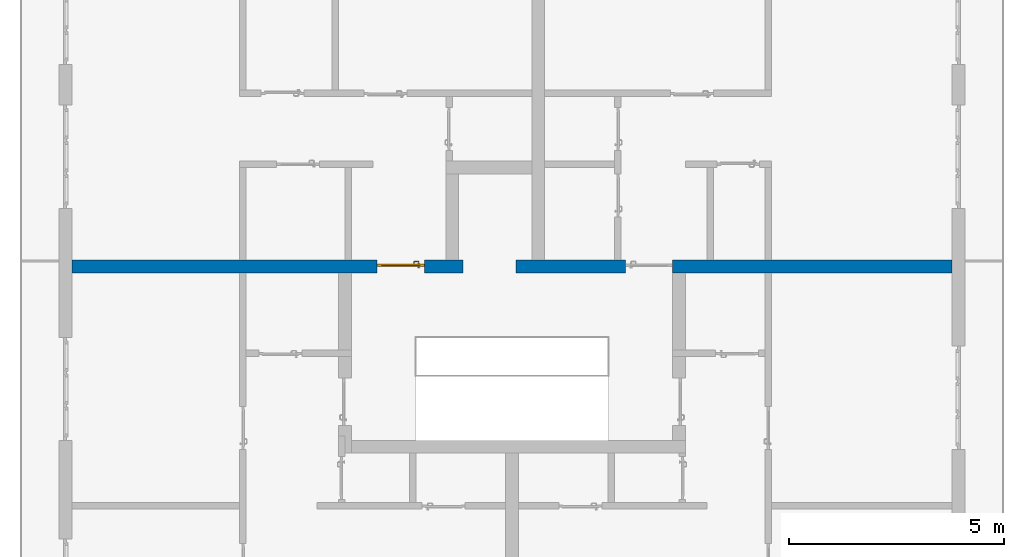
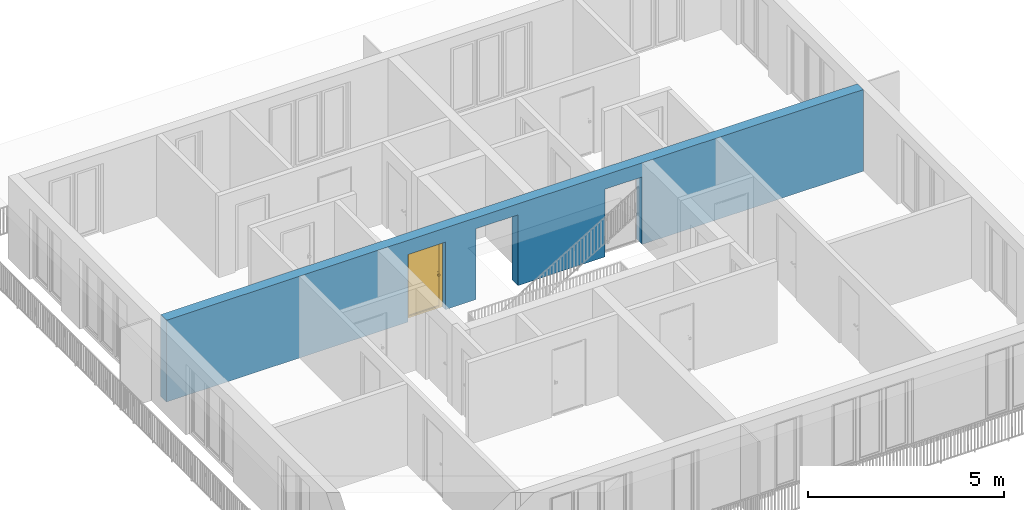
# One storey, part 16 of 54: 1 door, 1 wall, 3 openings.
"""IFC4 building model written with IfcOpenShell, lengths in metres."""

from ifc_helpers import new_model, entity, si_unit, converted_unit, derived_unit, direction, frame, origin_with_axes, place, context, subcontext, project, spatial, polygons, source, transform, mapped, material, type_object, element, fill, save


model = new_model("IFC4")

# Units and contexts
model_context = context("Model", 3, precision=1e-05, world=origin_with_axes(), true_north=direction((0.0, 1.0)))
body_context = subcontext(model_context, "Body", "Model", "MODEL_VIEW")
ifc_project = project(units=[si_unit("LENGTHUNIT", "METRE"), si_unit("AREAUNIT", "SQUARE_METRE"), si_unit("VOLUMEUNIT", "CUBIC_METRE"), converted_unit("PLANEANGLEUNIT", "DEGREE", entity("IfcPlaneAngleMeasure", 0.0174532925199), si_unit("PLANEANGLEUNIT", "RADIAN"), dimensions=[0, 0, 0, 0, 0, 0, 0]), converted_unit("TIMEUNIT", "Year", entity("IfcTimeMeasure", 31556926.0), si_unit("TIMEUNIT", "SECOND"), dimensions=[0, 0, 1, 0, 0, 0, 0]), si_unit("MASSUNIT", "GRAM", prefix="KILO"), si_unit("THERMODYNAMICTEMPERATUREUNIT", "DEGREE_CELSIUS"), si_unit("LUMINOUSINTENSITYUNIT", "LUMEN"), si_unit("ENERGYUNIT", "JOULE", prefix="MEGA"), derived_unit("THERMALCONDUCTANCEUNIT", [(si_unit("POWERUNIT", "WATT"), 1), (si_unit("LENGTHUNIT", "METRE"), -1), (si_unit("THERMODYNAMICTEMPERATUREUNIT", "KELVIN"), -1)]), derived_unit("SPECIFICHEATCAPACITYUNIT", [(si_unit("ENERGYUNIT", "JOULE"), 1), (si_unit("MASSUNIT", "GRAM", prefix="KILO"), -1), (si_unit("THERMODYNAMICTEMPERATUREUNIT", "KELVIN"), -1)]), derived_unit("MASSDENSITYUNIT", [(si_unit("MASSUNIT", "GRAM", prefix="KILO"), 1), (si_unit("VOLUMEUNIT", "CUBIC_METRE"), -1)])], contexts=[model_context])

# Site, building, storey
site_placement = place(None, origin_with_axes())
site = spatial("IfcSite", under=ifc_project, at=site_placement, CompositionType="ELEMENT")
building_placement = place(site_placement, origin_with_axes())
building = spatial("IfcBuilding", under=site, at=building_placement, CompositionType="ELEMENT")
storey_placement = place(building_placement, frame((0.0, 0.0, 6.29), z_axis=(0.0, 0.0, 1.0), x_axis=(1.0, 0.0, 0.0)))
storey = spatial("IfcBuildingStorey", under=building, at=storey_placement, Name="2. Geschoss", CompositionType="ELEMENT", Elevation=6.29)

# Wall, openings, door
ifc_material = material()
wall_type = type_object("IfcWallType", Name="300", PredefinedType="NOTDEFINED")
wall_placement = place(storey_placement, frame((-11.7421993804, 1.37118776896, 0.0), z_axis=(0.0, 0.0, 1.0), x_axis=(1.0, 0.0, 0.0)))
wall = element("IfcWall", 1, at=wall_placement, inside=storey, type_object=wall_type, material=ifc_material, Name="Wand-001", PredefinedType="NOTDEFINED", context=body_context, shape_type="Tessellation", body=[
    polygons([(9.4, 0.3, 2.2), (9.4, 0.3, 0.0), (8.5, 0.3, 0.0), (8.5, 0.3, 2.1), (7.4, 0.3, 2.1), (7.4, 0.3, 0.0), (0.3, 0.3, 0.0), (0.3, 0.3, 2.54), (20.78, 0.3, 2.54), (20.78, 0.3, 0.0), (14.28, 0.3, 0.0), (14.28, 0.3, 2.1), (13.18, 0.3, 2.1), (13.18, 0.3, 0.0), (10.63, 0.3, 0.0), (10.63, 0.3, 2.2), (9.4, 0.0, 2.2), (9.4, 0.0, 0.0), (8.5, 0.0, 0.0), (8.5, 0.0, 2.1), (7.4, 0.0, 2.1), (7.4, 0.0, 0.0), (0.3, 0.0, 0.0), (0.3, 0.0, 2.54), (20.78, 0.0, 2.54), (20.78, 0.0, 0.0), (14.28, 0.0, 0.0), (14.28, 0.0, 2.1), (13.18, 0.0, 2.1), (13.18, 0.0, 0.0), (10.63, 0.0, 0.0), (10.63, 0.0, 2.2)], [[[1, 2, 3, 4, 5, 6, 7, 8, 9, 10, 11, 12, 13, 14, 15, 16]], [[2, 1, 17, 18]], [[2, 18, 19, 3]], [[20, 4, 3, 19]], [[21, 5, 4, 20]], [[22, 6, 5, 21]], [[7, 6, 22, 23]], [[24, 8, 7, 23]], [[25, 9, 8, 24]], [[9, 25, 26, 10]], [[10, 26, 27, 11]], [[11, 27, 28, 12]], [[12, 28, 29, 13]], [[13, 29, 30, 14]], [[31, 15, 14, 30]], [[16, 15, 31, 32]], [[1, 16, 32, 17]], [[32, 31, 30, 29, 28, 27, 26, 25, 24, 23, 22, 21, 20, 19, 18, 17]]], closed=True),
])
opening_1_placement = place(wall_placement, frame((7.95, 0.0, 0.0), z_axis=(0.0, 0.0, 1.0), x_axis=(1.0, 0.0, 0.0)))
opening_1 = element("IfcOpeningElement", 2, at=opening_1_placement, cuts=wall, context=body_context, identifier="Reference", shape_type="Tessellation", body=[
    polygons([(0.55, 0.15, 0.0), (0.55, 0.15, 2.1), (0.55, -0.001, 2.1), (0.55, -0.001, 0.0), (0.55, 0.301, 0.0), (0.55, 0.301, 2.1), (-0.55, 0.15, 2.1), (-0.55, -0.001, 2.1), (-0.55, 0.301, 2.1), (-0.55, -0.001, 0.0), (-0.55, 0.15, 0.0), (-0.55, 0.301, 0.0)], [[[1, 2, 3, 4]], [[2, 1, 5, 6]], [[7, 8, 3, 2, 6, 9]], [[8, 10, 4, 3]], [[1, 4, 10, 11, 12, 5]], [[6, 5, 12, 9]], [[7, 11, 10, 8]], [[11, 7, 9, 12]]], closed=True),
])
opening_2_placement = place(wall_placement, frame((13.73, 0.0, 0.0), z_axis=(0.0, 0.0, 1.0), x_axis=(1.0, 0.0, 0.0)))
element("IfcOpeningElement", 3, at=opening_2_placement, cuts=wall, context=body_context, identifier="Reference", shape_type="Tessellation", body=[
    polygons([(0.55, 0.15, 0.0), (0.55, 0.15, 2.1), (0.55, -0.001, 2.1), (0.55, -0.001, 0.0), (0.55, 0.301, 0.0), (0.55, 0.301, 2.1), (-0.55, 0.15, 2.1), (-0.55, -0.001, 2.1), (-0.55, 0.301, 2.1), (-0.55, -0.001, 0.0), (-0.55, 0.15, 0.0), (-0.55, 0.301, 0.0)], [[[1, 2, 3, 4]], [[2, 1, 5, 6]], [[7, 8, 3, 2, 6, 9]], [[8, 10, 4, 3]], [[1, 4, 10, 11, 12, 5]], [[6, 5, 12, 9]], [[7, 11, 10, 8]], [[11, 7, 9, 12]]], closed=True),
])
opening_3_placement = place(wall_placement, frame((10.015, 0.0, 0.0), z_axis=(0.0, 0.0, 1.0), x_axis=(1.0, 0.0, 0.0)))
element("IfcOpeningElement", 4, at=opening_3_placement, cuts=wall, context=body_context, identifier="Reference", shape_type="Tessellation", body=[
    polygons([(-0.615, -0.001, 2.2), (-0.615, -0.001, 0.0), (0.615, -0.001, 0.0), (0.615, -0.001, 2.2), (-0.615, 0.301, 2.2), (-0.615, 0.301, 0.0), (0.615, 0.301, 0.0), (0.615, 0.301, 2.2)], [[[1, 2, 3, 4]], [[5, 6, 2, 1]], [[6, 7, 3, 2]], [[7, 8, 4, 3]], [[8, 5, 1, 4]], [[7, 6, 5, 8]]], closed=True),
])
door_type = type_object("IfcDoorType", Name="Eingang 01 1-Fl 26", OperationType="SINGLE_SWING_LEFT", PredefinedType="DOOR")
shared_shape = source(origin_with_axes(), body_context, "Body", "Tessellation", [
    polygons([(-0.55, -0.05, 0.0), (-0.55, -0.05, 2.1), (-0.55, -0.03, 2.1), (-0.55, -0.03, 0.0), (-0.45, -0.05, 0.0), (-0.45, -0.05, 2.0), (-0.1301, -0.05, 2.0), (-0.0001, -0.05, 2.0), (0.45, -0.05, 2.0), (0.45, -0.05, 0.0), (0.55, -0.05, 0.0), (0.55, -0.05, 2.1), (0.55, -0.03, 2.1), (0.55, -0.03, 0.0), (0.45, -0.03, 0.0), (0.45, -0.03, 2.0), (-0.0001, -0.03, 2.0), (-0.1301, -0.03, 2.0), (-0.45, -0.03, 2.0), (-0.45, -0.03, 0.0)], [[[1, 2, 3, 4]], [[1, 5, 6, 7, 8, 9, 10, 11, 12, 2]], [[2, 12, 13, 3]], [[4, 3, 13, 14, 15, 16, 17, 18, 19, 20]], [[5, 1, 4, 20]], [[6, 5, 20, 19]], [[7, 6, 19, 18]], [[8, 7, 18, 17]], [[9, 8, 17, 16]], [[10, 9, 16, 15]], [[11, 10, 15, 14]], [[12, 11, 14, 13]]], closed=True),
    polygons([(-0.55, -0.03, 0.0), (-0.55, -0.03, 2.1), (-0.55, 0.0, 2.1), (-0.55, 0.0, 0.0), (-0.48, -0.03, 0.0), (-0.48, -0.03, 2.03), (-0.1001, -0.03, 2.03), (-0.0301, -0.03, 2.03), (0.48, -0.03, 2.03), (0.48, -0.03, 0.0), (0.55, -0.03, 0.0), (0.55, -0.03, 2.1), (0.55, 0.0, 2.1), (0.55, 0.0, 0.0), (0.48, 0.0, 0.0), (0.48, 0.0, 2.03), (-0.0301, 0.0, 2.03), (-0.1001, 0.0, 2.03), (-0.48, 0.0, 2.03), (-0.48, 0.0, 0.0)], [[[1, 2, 3, 4]], [[1, 5, 6, 7, 8, 9, 10, 11, 12, 2]], [[2, 12, 13, 3]], [[4, 3, 13, 14, 15, 16, 17, 18, 19, 20]], [[5, 1, 4, 20]], [[6, 5, 20, 19]], [[7, 6, 19, 18]], [[8, 7, 18, 17]], [[9, 8, 17, 16]], [[10, 9, 16, 15]], [[11, 10, 15, 14]], [[12, 11, 14, 13]]], closed=True),
    polygons([(-0.48, 0.01, 0.0), (-0.48, 0.01, 2.03), (0.48, 0.01, 2.03), (0.48, 0.01, 0.0), (-0.48, -0.03, 0.0), (-0.48, -0.03, 2.03), (0.48, -0.03, 2.03), (0.48, -0.03, 0.0)], [[[1, 2, 3, 4]], [[1, 5, 6, 2]], [[2, 6, 7, 3]], [[3, 7, 8, 4]], [[4, 8, 5, 1]], [[8, 7, 6, 5]]], closed=True),
    polygons([(-0.445, -0.05, 0.0), (0.445, -0.05, 0.0), (0.445, -0.05, 0.05), (-0.445, -0.05, 0.05), (-0.445, -0.03, 0.0), (0.445, -0.03, 0.0), (0.445, -0.03, 0.07), (0.445, -0.035, 0.07), (-0.445, -0.035, 0.07), (-0.445, -0.03, 0.07)], [[[1, 2, 3, 4]], [[5, 6, 2, 1]], [[2, 6, 7, 8, 3]], [[4, 3, 8, 9]], [[1, 4, 9, 10, 5]], [[10, 7, 6, 5]], [[9, 8, 7, 10]]], closed=True),
    polygons([(0.4335, 0.02, 1.0733826859), (0.42, 0.02, 1.077), (0.42, 0.0199, 1.077), (0.4335, 0.0199, 1.0733826859), (0.443382685902, 0.02, 1.0635), (0.447, 0.02, 1.05), (0.443382685902, 0.02, 1.0365), (0.4335, 0.02, 1.0266173141), (0.42, 0.02, 1.023), (0.4065, 0.02, 1.0266173141), (0.396617314098, 0.02, 1.0365), (0.393, 0.02, 1.05), (0.396617314098, 0.02, 1.0635), (0.4065, 0.02, 1.0733826859), (0.4065, 0.0199, 1.0733826859), (0.42, 0.0101, 1.077), (0.4335, 0.0101, 1.0733826859), (0.443382685902, 0.0199, 1.0635), (0.447, 0.0199, 1.05), (0.443382685902, 0.0199, 1.0365), (0.4335, 0.0199, 1.0266173141), (0.42, 0.0199, 1.023), (0.4065, 0.0199, 1.0266173141), (0.396617314098, 0.0199, 1.0365), (0.393, 0.0199, 1.05), (0.396617314098, 0.0199, 1.0635), (0.4065, 0.0101, 1.0733826859), (0.42, 0.01, 1.077), (0.4335, 0.01, 1.0733826859), (0.443382685902, 0.0101, 1.0635), (0.447, 0.0101, 1.05), (0.443382685902, 0.0101, 1.0365), (0.4335, 0.0101, 1.0266173141), (0.42, 0.0101, 1.023), (0.4065, 0.0101, 1.0266173141), (0.396617314098, 0.0101, 1.0365), (0.393, 0.0101, 1.05), (0.396617314098, 0.0101, 1.0635), (0.4065, 0.01, 1.0733826859), (0.396617314098, 0.01, 1.0635), (0.393, 0.01, 1.05), (0.396617314098, 0.01, 1.0365), (0.4065, 0.01, 1.0266173141), (0.42, 0.01, 1.023), (0.4335, 0.01, 1.0266173141), (0.443382685902, 0.01, 1.0365), (0.447, 0.01, 1.05), (0.443382685902, 0.01, 1.0635)], [[[1, 2, 3, 4]], [[2, 1, 5, 6, 7, 8, 9, 10, 11, 12, 13, 14]], [[2, 14, 15, 3]], [[4, 3, 16, 17]], [[5, 1, 4, 18]], [[6, 5, 18, 19]], [[7, 6, 19, 20]], [[8, 7, 20, 21]], [[9, 8, 21, 22]], [[10, 9, 22, 23]], [[11, 10, 23, 24]], [[12, 11, 24, 25]], [[13, 12, 25, 26]], [[14, 13, 26, 15]], [[3, 15, 27, 16]], [[17, 16, 28, 29]], [[18, 4, 17, 30]], [[19, 18, 30, 31]], [[20, 19, 31, 32]], [[21, 20, 32, 33]], [[22, 21, 33, 34]], [[23, 22, 34, 35]], [[24, 23, 35, 36]], [[25, 24, 36, 37]], [[26, 25, 37, 38]], [[15, 26, 38, 27]], [[16, 27, 39, 28]], [[28, 39, 40, 41, 42, 43, 44, 45, 46, 47, 48, 29]], [[30, 17, 29, 48]], [[31, 30, 48, 47]], [[32, 31, 47, 46]], [[33, 32, 46, 45]], [[34, 33, 45, 44]], [[35, 34, 44, 43]], [[36, 35, 43, 42]], [[37, 36, 42, 41]], [[38, 37, 41, 40]], [[27, 38, 40, 39]]], closed=True),
    polygons([(0.412532169224, 0.019, 0.959692280177), (0.413279754556, 0.019, 0.961639806549), (0.40705, 0.019, 0.972430057958), (0.397569942042, 0.019, 0.96295), (0.415, 0.019, 0.952886751346), (0.415, 0.019, 0.9544), (0.412532169224, 0.02, 0.959692280177), (0.413279754556, 0.02, 0.961639806549), (0.414624817685, 0.02, 0.965143815798), (0.414624817685, 0.019, 0.965143815798), (0.42, 0.019, 0.967425445323), (0.42, 0.019, 0.9759), (0.407, 0.019, 0.972516660498), (0.397483339502, 0.019, 0.963), (0.415, 0.019, 0.95), (0.3941, 0.019, 0.95), (0.415, 0.019, 0.947113248654), (0.415, 0.019, 0.941339745962), (0.415, 0.019, 0.9375), (0.415, 0.02, 0.9375), (0.415, 0.02, 0.941339745962), (0.415, 0.02, 0.947113248654), (0.415, 0.02, 0.95), (0.415, 0.02, 0.952886751346), (0.415, 0.02, 0.9544), (0.396703916638, 0.02, 0.96345), (0.40655, 0.02, 0.973296083362), (0.42, 0.02, 0.9769), (0.42, 0.02, 0.967425445323), (0.425375182315, 0.019, 0.965143815798), (0.426720245444, 0.019, 0.961639806549), (0.43295, 0.019, 0.972430057958), (0.42, 0.019, 0.976), (0.407, 0.0189, 0.972516660498), (0.397483339502, 0.0189, 0.963), (0.394, 0.019, 0.95), (0.397569942042, 0.019, 0.93705), (0.40705, 0.019, 0.927569942042), (0.42, 0.019, 0.9241), (0.42, 0.019, 0.9325), (0.416464466094, 0.019, 0.933964466094), (0.416464466094, 0.02, 0.933964466094), (0.42, 0.02, 0.9231), (0.40655, 0.02, 0.926703916638), (0.42, 0.02, 0.9325), (0.396703916638, 0.02, 0.93655), (0.3931, 0.02, 0.95), (0.396617314098, 0.02, 0.9635), (0.4065, 0.02, 0.973382685902), (0.42, 0.02, 0.977), (0.425375182315, 0.02, 0.965143815798), (0.43345, 0.02, 0.973296083362), (0.426720245444, 0.02, 0.961639806549), (0.427467830776, 0.02, 0.959692280177), (0.427467830776, 0.019, 0.959692280177), (0.425, 0.019, 0.9544), (0.425, 0.019, 0.952886751346), (0.442430057958, 0.019, 0.96295), (0.433, 0.019, 0.972516660498), (0.42, 0.0189, 0.976), (0.407, 0.0101, 0.972516660498), (0.397483339502, 0.0101, 0.963), (0.394, 0.0189, 0.95), (0.397483339502, 0.019, 0.937), (0.407, 0.019, 0.927483339502), (0.42, 0.019, 0.924), (0.43295, 0.019, 0.927569942042), (0.425, 0.019, 0.941339745962), (0.425, 0.019, 0.9375), (0.423535533906, 0.019, 0.933964466094), (0.42, 0.02, 0.923), (0.4065, 0.02, 0.926617314098), (0.43345, 0.02, 0.926703916638), (0.423535533906, 0.02, 0.933964466094), (0.425, 0.02, 0.9375), (0.425, 0.02, 0.941339745962), (0.396617314098, 0.02, 0.9365), (0.393, 0.02, 0.95), (0.396617314098, 0.0199, 0.9635), (0.4065, 0.0199, 0.973382685902), (0.42, 0.0199, 0.977), (0.4335, 0.02, 0.973382685902), (0.443296083362, 0.02, 0.96345), (0.425, 0.02, 0.952886751346), (0.425, 0.02, 0.9544), (0.425, 0.02, 0.95), (0.425, 0.02, 0.947113248654), (0.425, 0.019, 0.947113248654), (0.425, 0.019, 0.95), (0.4459, 0.019, 0.95), (0.442516660498, 0.019, 0.963), (0.433, 0.0189, 0.972516660498), (0.42, 0.0101, 0.976), (0.407, 0.01, 0.972516660498), (0.397483339502, 0.01, 0.963), (0.394, 0.0101, 0.95), (0.397483339502, 0.0189, 0.937), (0.407, 0.0189, 0.927483339502), (0.42, 0.0189, 0.924), (0.433, 0.019, 0.927483339502), (0.442430057958, 0.019, 0.93705), (0.42, 0.0199, 0.923), (0.4065, 0.0199, 0.926617314098), (0.4335, 0.02, 0.926617314098), (0.443296083362, 0.02, 0.93655), (0.396617314098, 0.0199, 0.9365), (0.393, 0.0199, 0.95), (0.396617314098, 0.0101, 0.9635), (0.4065, 0.0101, 0.973382685902), (0.42, 0.0101, 0.977), (0.4335, 0.0199, 0.973382685902), (0.443382685902, 0.02, 0.9635), (0.4469, 0.02, 0.95), (0.446, 0.019, 0.95), (0.442516660498, 0.0189, 0.963), (0.433, 0.0101, 0.972516660498), (0.42, 0.01, 0.976), (0.40695, 0.01, 0.972603263039), (0.397396736961, 0.01, 0.96305), (0.394, 0.01, 0.95), (0.397483339502, 0.0101, 0.937), (0.407, 0.0101, 0.927483339502), (0.42, 0.0101, 0.924), (0.433, 0.0189, 0.927483339502), (0.442516660498, 0.019, 0.937), (0.42, 0.0101, 0.923), (0.4065, 0.0101, 0.926617314098), (0.4335, 0.0199, 0.926617314098), (0.443382685902, 0.02, 0.9365), (0.396617314098, 0.0101, 0.9365), (0.393, 0.0101, 0.95), (0.396617314098, 0.01, 0.9635), (0.4065, 0.01, 0.973382685902), (0.42, 0.01, 0.977), (0.4335, 0.0101, 0.973382685902), (0.443382685902, 0.0199, 0.9635), (0.447, 0.02, 0.95), (0.446, 0.0189, 0.95), (0.442516660498, 0.0101, 0.963), (0.433, 0.01, 0.972516660498), (0.42, 0.01, 0.9761), (0.40655, 0.01, 0.973296083362), (0.396703916638, 0.01, 0.96345), (0.3939, 0.01, 0.95), (0.397483339502, 0.01, 0.937), (0.407, 0.01, 0.927483339502), (0.42, 0.01, 0.924), (0.433, 0.0101, 0.927483339502), (0.442516660498, 0.0189, 0.937), (0.42, 0.01, 0.923), (0.4065, 0.01, 0.926617314098), (0.4335, 0.0101, 0.926617314098), (0.443382685902, 0.0199, 0.9365), (0.396617314098, 0.01, 0.9365), (0.393, 0.01, 0.95), (0.42, 0.01, 0.9769), (0.4335, 0.01, 0.973382685902), (0.443382685902, 0.0101, 0.9635), (0.447, 0.0199, 0.95), (0.446, 0.0101, 0.95), (0.442516660498, 0.01, 0.963), (0.43305, 0.01, 0.972603263039), (0.3931, 0.01, 0.95), (0.397396736961, 0.01, 0.93695), (0.40695, 0.01, 0.927396736961), (0.42, 0.01, 0.9239), (0.433, 0.01, 0.927483339502), (0.442516660498, 0.0101, 0.937), (0.42, 0.01, 0.9231), (0.40655, 0.01, 0.926703916638), (0.4335, 0.01, 0.926617314098), (0.443382685902, 0.0101, 0.9365), (0.396703916638, 0.01, 0.93655), (0.43345, 0.01, 0.973296083362), (0.443382685902, 0.01, 0.9635), (0.447, 0.0101, 0.95), (0.446, 0.01, 0.95), (0.442603263039, 0.01, 0.96305), (0.43305, 0.01, 0.927396736961), (0.442516660498, 0.01, 0.937), (0.43345, 0.01, 0.926703916638), (0.443382685902, 0.01, 0.9365), (0.443296083362, 0.01, 0.96345), (0.447, 0.01, 0.95), (0.4461, 0.01, 0.95), (0.442603263039, 0.01, 0.93695), (0.443296083362, 0.01, 0.93655), (0.4469, 0.01, 0.95)], [[[1, 2, 3, 4, 5, 6]], [[1, 7, 8, 9, 10, 2]], [[10, 11, 12, 3, 2]], [[4, 3, 13, 14]], [[15, 5, 4, 16]], [[6, 5, 15, 17, 18, 19, 20, 21, 22, 23, 24, 25]], [[6, 25, 7, 1]], [[7, 25, 24, 26, 27, 8]], [[9, 8, 27, 28, 29]], [[10, 9, 29, 11]], [[30, 31, 32, 12, 11]], [[3, 12, 33, 13]], [[14, 13, 34, 35]], [[16, 4, 14, 36]], [[17, 15, 16, 37]], [[18, 17, 37, 38]], [[38, 39, 40, 41, 19, 18]], [[19, 41, 42, 20]], [[43, 44, 21, 20, 42, 45]], [[22, 21, 44, 46]], [[23, 22, 46, 47]], [[24, 23, 47, 26]], [[48, 49, 27, 26]], [[49, 50, 28, 27]], [[51, 29, 28, 52, 53]], [[11, 29, 51, 30]], [[30, 51, 53, 54, 55, 31]], [[55, 56, 57, 58, 32, 31]], [[12, 32, 59, 33]], [[13, 33, 60, 34]], [[35, 34, 61, 62]], [[36, 14, 35, 63]], [[37, 16, 36, 64]], [[38, 37, 64, 65]], [[39, 38, 65, 66]], [[39, 67, 68, 69, 70, 40]], [[41, 40, 45, 42]], [[71, 72, 44, 43]], [[73, 43, 45, 74, 75, 76]], [[72, 77, 46, 44]], [[77, 78, 47, 46]], [[78, 48, 26, 47]], [[79, 80, 49, 48]], [[80, 81, 50, 49]], [[50, 82, 52, 28]], [[54, 53, 52, 83, 84, 85]], [[55, 54, 85, 56]], [[85, 84, 86, 87, 76, 75, 69, 68, 88, 89, 57, 56]], [[57, 89, 90, 58]], [[32, 58, 91, 59]], [[33, 59, 92, 60]], [[34, 60, 93, 61]], [[62, 61, 94, 95]], [[63, 35, 62, 96]], [[64, 36, 63, 97]], [[65, 64, 97, 98]], [[66, 65, 98, 99]], [[67, 39, 66, 100]], [[88, 68, 67, 101]], [[70, 69, 75, 74]], [[40, 70, 74, 45]], [[102, 103, 72, 71]], [[104, 71, 43, 73]], [[76, 87, 105, 73]], [[103, 106, 77, 72]], [[106, 107, 78, 77]], [[107, 79, 48, 78]], [[108, 109, 80, 79]], [[109, 110, 81, 80]], [[81, 111, 82, 50]], [[82, 112, 83, 52]], [[86, 84, 83, 113]], [[87, 86, 113, 105]], [[89, 88, 101, 90]], [[58, 90, 114, 91]], [[59, 91, 115, 92]], [[60, 92, 116, 93]], [[61, 93, 117, 94]], [[95, 94, 118, 119]], [[96, 62, 95, 120]], [[97, 63, 96, 121]], [[98, 97, 121, 122]], [[99, 98, 122, 123]], [[100, 66, 99, 124]], [[101, 67, 100, 125]], [[126, 127, 103, 102]], [[128, 102, 71, 104]], [[129, 104, 73, 105]], [[127, 130, 106, 103]], [[130, 131, 107, 106]], [[131, 108, 79, 107]], [[132, 133, 109, 108]], [[133, 134, 110, 109]], [[110, 135, 111, 81]], [[111, 136, 112, 82]], [[112, 137, 113, 83]], [[137, 129, 105, 113]], [[90, 101, 125, 114]], [[91, 114, 138, 115]], [[92, 115, 139, 116]], [[93, 116, 140, 117]], [[94, 117, 141, 118]], [[119, 118, 142, 143]], [[120, 95, 119, 144]], [[121, 96, 120, 145]], [[122, 121, 145, 146]], [[123, 122, 146, 147]], [[124, 99, 123, 148]], [[125, 100, 124, 149]], [[150, 151, 127, 126]], [[152, 126, 102, 128]], [[153, 128, 104, 129]], [[151, 154, 130, 127]], [[154, 155, 131, 130]], [[155, 132, 108, 131]], [[143, 142, 133, 132]], [[142, 156, 134, 133]], [[134, 157, 135, 110]], [[135, 158, 136, 111]], [[136, 159, 137, 112]], [[159, 153, 129, 137]], [[114, 125, 149, 138]], [[115, 138, 160, 139]], [[116, 139, 161, 140]], [[117, 140, 162, 141]], [[118, 141, 156, 142]], [[144, 119, 143, 163]], [[145, 120, 144, 164]], [[146, 145, 164, 165]], [[147, 146, 165, 166]], [[148, 123, 147, 167]], [[149, 124, 148, 168]], [[169, 170, 151, 150]], [[171, 150, 126, 152]], [[172, 152, 128, 153]], [[170, 173, 154, 151]], [[173, 163, 155, 154]], [[163, 143, 132, 155]], [[156, 174, 157, 134]], [[157, 175, 158, 135]], [[158, 176, 159, 136]], [[176, 172, 153, 159]], [[138, 149, 168, 160]], [[139, 160, 177, 161]], [[140, 161, 178, 162]], [[141, 162, 174, 156]], [[164, 144, 163, 173]], [[165, 164, 173, 170]], [[166, 165, 170, 169]], [[167, 147, 166, 179]], [[168, 148, 167, 180]], [[181, 169, 150, 171]], [[182, 171, 152, 172]], [[174, 183, 175, 157]], [[175, 184, 176, 158]], [[184, 182, 172, 176]], [[160, 168, 180, 177]], [[161, 177, 185, 178]], [[162, 178, 183, 174]], [[179, 166, 169, 181]], [[180, 167, 179, 186]], [[187, 181, 171, 182]], [[183, 188, 184, 175]], [[188, 187, 182, 184]], [[177, 180, 186, 185]], [[178, 185, 188, 183]], [[186, 179, 181, 187]], [[185, 186, 187, 188]]], closed=True),
    polygons([(0.43, 0.02, 1.05), (0.427071067812, 0.02, 1.04292893219), (0.427071067812, 0.050696439392, 1.04292893219), (0.43, 0.0509849140336, 1.05), (0.42, 0.02, 1.04), (0.42, 0.05, 1.04), (0.425518993221, 0.0584992452783, 1.04292893219), (0.428277987014, 0.0596420579258, 1.05), (0.427071067812, 0.02, 1.05707106781), (0.427071067812, 0.050696439392, 1.05707106781), (0.412928932188, 0.02, 1.04292893219), (0.412928932188, 0.049303560608, 1.04292893219), (0.418858192988, 0.0557402514855, 1.04), (0.420704557509, 0.0657045575088, 1.04292893219), (0.422816199938, 0.0678161999379, 1.05), (0.425518993221, 0.0584992452783, 1.05707106781), (0.42, 0.02, 1.06), (0.42, 0.05, 1.06), (0.41, 0.02, 1.05), (0.41, 0.0490150859664, 1.05), (0.412197392755, 0.0529812576926, 1.04292893219), (0.415606601718, 0.0606066017178, 1.04), (0.413499245278, 0.0705189932208, 1.04292893219), (0.414642057926, 0.0732779870137, 1.05), (0.420704557509, 0.0657045575088, 1.05707106781), (0.418858192988, 0.0557402514855, 1.06), (0.412928932188, 0.02, 1.05707106781), (0.412928932188, 0.049303560608, 1.05707106781), (0.409438398962, 0.0518384450452, 1.05), (0.410508645927, 0.0555086459268, 1.04292893219), (0.410740251485, 0.0638581929877, 1.04), (0.405696439392, 0.0720710678119, 1.04292893219), (0.405984914034, 0.075, 1.05), (0.413499245278, 0.0705189932208, 1.05707106781), (0.415606601718, 0.0606066017178, 1.06), (0.412197392755, 0.0529812576926, 1.05707106781), (0.408397003498, 0.0533970034977, 1.05), (0.407981257693, 0.0571973927545, 1.04292893219), (0.405, 0.065, 1.04), (0.324303560608, 0.0720710678119, 1.04292893219), (0.324015085966, 0.075, 1.05), (0.405696439392, 0.0720710678119, 1.05707106781), (0.410740251485, 0.0638581929877, 1.06), (0.410508645927, 0.0555086459268, 1.05707106781), (0.406838445045, 0.0544383989617, 1.05), (0.404303560608, 0.0579289321881, 1.04292893219), (0.325, 0.065, 1.04), (0.316500754722, 0.0705189932208, 1.04292893219), (0.315357942074, 0.0732779870137, 1.05), (0.324303560608, 0.0720710678119, 1.05707106781), (0.405, 0.065, 1.06), (0.407981257693, 0.0571973927545, 1.05707106781), (0.404015085966, 0.055, 1.05), (0.325696439392, 0.0579289321881, 1.04292893219), (0.319259748515, 0.0638581929877, 1.04), (0.309295442491, 0.0657045575088, 1.04292893219), (0.307183800062, 0.0678161999379, 1.05), (0.316500754722, 0.0705189932208, 1.05707106781), (0.325, 0.065, 1.06), (0.404303560608, 0.0579289321881, 1.05707106781), (0.325984914034, 0.055, 1.05), (0.322018742307, 0.0571973927545, 1.04292893219), (0.314393398282, 0.0606066017178, 1.04), (0.304481006779, 0.0584992452783, 1.04292893219), (0.301722012986, 0.0596420579258, 1.05), (0.309295442491, 0.0657045575088, 1.05707106781), (0.319259748515, 0.0638581929877, 1.06), (0.325696439392, 0.0579289321881, 1.05707106781), (0.323161554955, 0.0544383989617, 1.05), (0.319491354073, 0.0555086459268, 1.04292893219), (0.311141807012, 0.0557402514855, 1.04), (0.302928932188, 0.050696439392, 1.04292893219), (0.3, 0.0509849140336, 1.05), (0.304481006779, 0.0584992452783, 1.05707106781), (0.314393398282, 0.0606066017178, 1.06), (0.322018742307, 0.0571973927545, 1.05707106781), (0.321602996502, 0.0533970034977, 1.05), (0.317802607245, 0.0529812576926, 1.04292893219), (0.31, 0.05, 1.04), (0.302928932188, 0.02, 1.04292893219), (0.3, 0.02, 1.05), (0.302928932188, 0.050696439392, 1.05707106781), (0.311141807012, 0.0557402514855, 1.06), (0.319491354073, 0.0555086459268, 1.05707106781), (0.320561601038, 0.0518384450452, 1.05), (0.317071067812, 0.049303560608, 1.04292893219), (0.31, 0.02, 1.04), (0.317071067812, 0.02, 1.04292893219), (0.32, 0.02, 1.05), (0.317071067812, 0.02, 1.05707106781), (0.31, 0.02, 1.06), (0.302928932188, 0.02, 1.05707106781), (0.31, 0.05, 1.06), (0.317802607245, 0.0529812576926, 1.05707106781), (0.32, 0.0490150859664, 1.05), (0.317071067812, 0.049303560608, 1.05707106781)], [[[1, 2, 3, 4]], [[2, 5, 6, 3]], [[4, 3, 7, 8]], [[9, 1, 4, 10]], [[5, 11, 12, 6]], [[3, 6, 13, 7]], [[8, 7, 14, 15]], [[10, 4, 8, 16]], [[17, 9, 10, 18]], [[11, 19, 20, 12]], [[6, 12, 21, 13]], [[7, 13, 22, 14]], [[15, 14, 23, 24]], [[16, 8, 15, 25]], [[18, 10, 16, 26]], [[27, 17, 18, 28]], [[19, 27, 28, 20]], [[12, 20, 29, 21]], [[13, 21, 30, 22]], [[14, 22, 31, 23]], [[24, 23, 32, 33]], [[25, 15, 24, 34]], [[26, 16, 25, 35]], [[28, 18, 26, 36]], [[20, 28, 36, 29]], [[21, 29, 37, 30]], [[22, 30, 38, 31]], [[23, 31, 39, 32]], [[33, 32, 40, 41]], [[34, 24, 33, 42]], [[35, 25, 34, 43]], [[36, 26, 35, 44]], [[29, 36, 44, 37]], [[30, 37, 45, 38]], [[31, 38, 46, 39]], [[32, 39, 47, 40]], [[41, 40, 48, 49]], [[42, 33, 41, 50]], [[43, 34, 42, 51]], [[44, 35, 43, 52]], [[37, 44, 52, 45]], [[38, 45, 53, 46]], [[39, 46, 54, 47]], [[40, 47, 55, 48]], [[49, 48, 56, 57]], [[50, 41, 49, 58]], [[51, 42, 50, 59]], [[52, 43, 51, 60]], [[45, 52, 60, 53]], [[46, 53, 61, 54]], [[47, 54, 62, 55]], [[48, 55, 63, 56]], [[57, 56, 64, 65]], [[58, 49, 57, 66]], [[59, 50, 58, 67]], [[60, 51, 59, 68]], [[53, 60, 68, 61]], [[54, 61, 69, 62]], [[55, 62, 70, 63]], [[56, 63, 71, 64]], [[65, 64, 72, 73]], [[66, 57, 65, 74]], [[67, 58, 66, 75]], [[68, 59, 67, 76]], [[61, 68, 76, 69]], [[62, 69, 77, 70]], [[63, 70, 78, 71]], [[64, 71, 79, 72]], [[73, 72, 80, 81]], [[74, 65, 73, 82]], [[75, 66, 74, 83]], [[76, 67, 75, 84]], [[69, 76, 84, 77]], [[70, 77, 85, 78]], [[71, 78, 86, 79]], [[72, 79, 87, 80]], [[81, 80, 87, 88, 89, 90, 91, 92]], [[82, 73, 81, 92]], [[83, 74, 82, 93]], [[84, 75, 83, 94]], [[77, 84, 94, 85]], [[78, 85, 95, 86]], [[79, 86, 88, 87]], [[86, 95, 89, 88]], [[95, 96, 90, 89]], [[96, 93, 91, 90]], [[93, 82, 92, 91]], [[94, 83, 93, 96]], [[85, 94, 96, 95]]], closed=False),
    polygons([(0.414696699141, -0.035, 1.04469669914), (0.4125, -0.035, 1.05), (0.414696699141, -0.035, 1.05530330086), (0.42, -0.035, 1.0575), (0.425303300859, -0.035, 1.05530330086), (0.4275, -0.035, 1.05), (0.425303300859, -0.035, 1.04469669914), (0.42, -0.035, 1.0425), (0.414696699141, -0.075, 1.04469669914), (0.4125, -0.075, 1.05), (0.414696699141, -0.075, 1.05530330086), (0.42, -0.075, 1.0575), (0.425303300859, -0.075, 1.05530330086), (0.4275, -0.075, 1.05), (0.425303300859, -0.075, 1.04469669914), (0.42, -0.075, 1.0425)], [[[1, 2, 3, 4, 5, 6, 7, 8]], [[1, 9, 10, 2]], [[2, 10, 11, 3]], [[3, 11, 12, 4]], [[4, 12, 13, 5]], [[5, 13, 14, 6]], [[6, 14, 15, 7]], [[7, 15, 16, 8]], [[8, 16, 9, 1]], [[9, 16, 15, 14, 13, 12, 11, 10]]], closed=True),
    polygons([(0.445, -0.03, 0.975), (0.445, -0.035, 0.975), (0.443096988313, -0.035, 0.965432914191), (0.443096988313, -0.03, 0.965432914191), (0.445, -0.03, 1.1), (0.445, -0.035, 1.1), (0.443096988313, -0.035, 1.10956708581), (0.43767766953, -0.035, 1.11767766953), (0.429567085809, -0.035, 1.12309698831), (0.42, -0.035, 1.125), (0.410432914191, -0.035, 1.12309698831), (0.40232233047, -0.035, 1.11767766953), (0.396903011687, -0.035, 1.10956708581), (0.395, -0.035, 1.1), (0.395, -0.035, 0.975), (0.396903011687, -0.035, 0.965432914191), (0.40232233047, -0.035, 0.95732233047), (0.410432914191, -0.035, 0.951903011687), (0.42, -0.035, 0.95), (0.429567085809, -0.035, 0.951903011687), (0.43767766953, -0.035, 0.95732233047), (0.43767766953, -0.03, 0.95732233047), (0.429567085809, -0.03, 0.951903011687), (0.42, -0.03, 0.95), (0.410432914191, -0.03, 0.951903011687), (0.40232233047, -0.03, 0.95732233047), (0.396903011687, -0.03, 0.965432914191), (0.395, -0.03, 0.975), (0.395, -0.03, 1.1), (0.396903011687, -0.03, 1.10956708581), (0.40232233047, -0.03, 1.11767766953), (0.410432914191, -0.03, 1.12309698831), (0.42, -0.03, 1.125), (0.429567085809, -0.03, 1.12309698831), (0.43767766953, -0.03, 1.11767766953), (0.443096988313, -0.03, 1.10956708581)], [[[1, 2, 3, 4]], [[5, 6, 2, 1]], [[2, 6, 7, 8, 9, 10, 11, 12, 13, 14, 15, 16, 17, 18, 19, 20, 21, 3]], [[4, 3, 21, 22]], [[1, 4, 22, 23, 24, 25, 26, 27, 28, 29, 30, 31, 32, 33, 34, 35, 36, 5]], [[36, 7, 6, 5]], [[35, 8, 7, 36]], [[34, 9, 8, 35]], [[33, 10, 9, 34]], [[32, 11, 10, 33]], [[31, 12, 11, 32]], [[30, 13, 12, 31]], [[29, 14, 13, 30]], [[28, 15, 14, 29]], [[27, 16, 15, 28]], [[26, 17, 16, 27]], [[25, 18, 17, 26]], [[24, 19, 18, 25]], [[23, 20, 19, 24]], [[22, 21, 20, 23]]], closed=True),
    polygons([(0.44, -0.075, 1.08), (0.44, -0.09, 1.08), (0.445, -0.09, 1.07866025404), (0.445, -0.075, 1.07866025404), (0.4, -0.075, 1.08), (0.4, -0.09, 1.08), (0.395, -0.09, 1.07866025404), (0.391339745962, -0.09, 1.075), (0.39, -0.09, 1.07), (0.39, -0.09, 1.03), (0.391339745962, -0.09, 1.025), (0.395, -0.09, 1.02133974596), (0.4, -0.09, 1.02), (0.44, -0.09, 1.02), (0.445, -0.09, 1.02133974596), (0.448660254038, -0.09, 1.025), (0.45, -0.09, 1.03), (0.45, -0.09, 1.07), (0.448660254038, -0.09, 1.075), (0.448660254038, -0.075, 1.075), (0.45, -0.075, 1.07), (0.45, -0.075, 1.03), (0.448660254038, -0.075, 1.025), (0.445, -0.075, 1.02133974596), (0.44, -0.075, 1.02), (0.4, -0.075, 1.02), (0.395, -0.075, 1.02133974596), (0.391339745962, -0.075, 1.025), (0.39, -0.075, 1.03), (0.39, -0.075, 1.07), (0.391339745962, -0.075, 1.075), (0.395, -0.075, 1.07866025404)], [[[1, 2, 3, 4]], [[5, 6, 2, 1]], [[2, 6, 7, 8, 9, 10, 11, 12, 13, 14, 15, 16, 17, 18, 19, 3]], [[4, 3, 19, 20]], [[1, 4, 20, 21, 22, 23, 24, 25, 26, 27, 28, 29, 30, 31, 32, 5]], [[32, 7, 6, 5]], [[31, 8, 7, 32]], [[30, 9, 8, 31]], [[29, 10, 9, 30]], [[28, 11, 10, 29]], [[27, 12, 11, 28]], [[26, 13, 12, 27]], [[25, 14, 13, 26]], [[24, 15, 14, 25]], [[23, 16, 15, 24]], [[22, 17, 16, 23]], [[21, 18, 17, 22]], [[20, 19, 18, 21]]], closed=True),
])
door_placement = place(opening_1_placement, frame((-0.45, 0.0, 0.0), z_axis=(0.0, 0.0, 1.0), x_axis=(1.0, 0.0, 0.0)))
door = element("IfcDoor", 5, at=door_placement, inside=storey, type_object=door_type, OverallHeight=2.1, OverallWidth=1.1, PredefinedType="DOOR", context=body_context, shape_type="MappedRepresentation", body=[
    mapped(shared_shape, transform((0.45, 0.2, 0.0))),
])
fill(opening_1, door)

save(model, "model.ifc")
